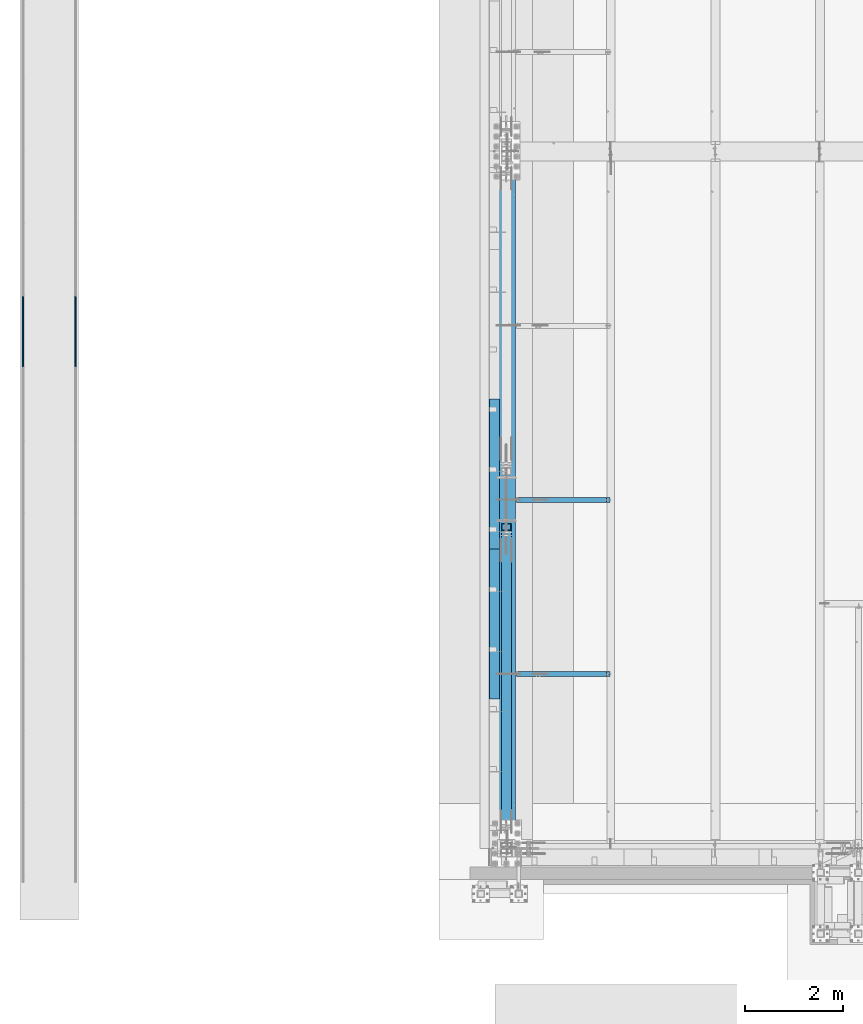
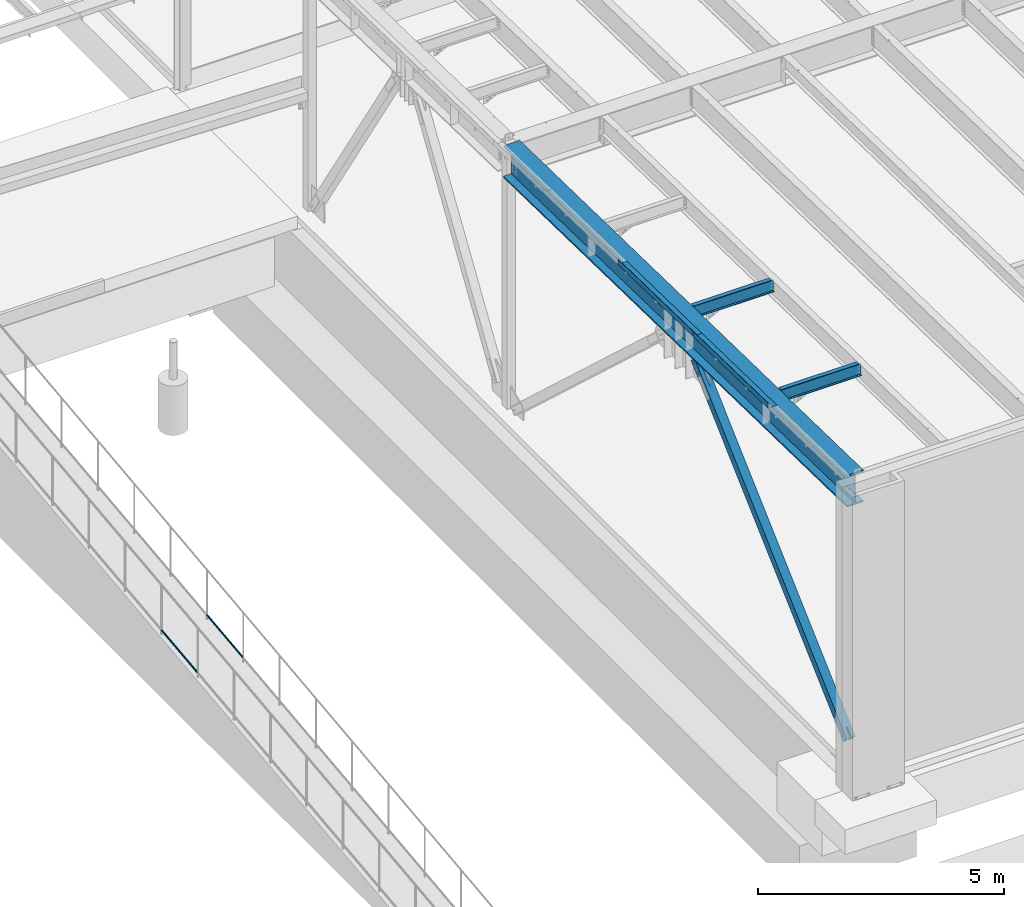
# One storey, part 1035 of 1763: 7 beams, 1 member, 6 elements without a shape of their own.
"""IFC2X3 building model written with IfcOpenShell, lengths in millimetres."""

from ifc_helpers import new_model, si_unit, frame, origin_with_axes, place, context, subcontext, project, spatial, faceted_brep, material, type_object, element, aggregate, save


model = new_model("IFC2X3")

# Units and contexts
model_context = context("Model", 3, precision=1e-05, world=origin_with_axes())
body_context = subcontext(model_context, "Body", "Model", "MODEL_VIEW")
ifc_project = project(units=[si_unit("LENGTHUNIT", "METRE", prefix="MILLI"), si_unit("AREAUNIT", "SQUARE_METRE"), si_unit("VOLUMEUNIT", "CUBIC_METRE"), si_unit("MASSUNIT", "GRAM", prefix="KILO"), si_unit("TIMEUNIT", "SECOND"), si_unit("PLANEANGLEUNIT", "RADIAN"), si_unit("SOLIDANGLEUNIT", "STERADIAN"), si_unit("THERMODYNAMICTEMPERATUREUNIT", "DEGREE_CELSIUS"), si_unit("LUMINOUSINTENSITYUNIT", "LUMEN")], contexts=[model_context])

# Site, building, storey
site_placement = place(None, origin_with_axes())
site = spatial("IfcSite", under=ifc_project, at=site_placement, CompositionType="ELEMENT")
building_placement = place(site_placement, origin_with_axes())
building = spatial("IfcBuilding", under=site, at=building_placement, Name="Undefined", CompositionType="ELEMENT")
storey_placement = place(building_placement, origin_with_axes())
storey = spatial("IfcBuildingStorey", under=building, at=storey_placement, Name="Undefined", CompositionType="ELEMENT", Elevation=0.0)

# Assembly, beam
assembly_1_placement = place(storey_placement, origin_with_axes())
assembly_1 = element("IfcElementAssembly", 1, at=assembly_1_placement, inside=storey, Name="GUARDRAIL", AssemblyPlace="NOTDEFINED", PredefinedType="RIGID_FRAME")
ifc_material_1 = material(Name="STEEL/A513")
beam_type_1 = type_object("IfcBeamType", PredefinedType="NOTDEFINED")
beam_1_placement = place(assembly_1_placement, frame((-97200.6527017878, -3943.56212109816, 4830.43051081101), z_axis=(0.0, -0.114062593029902, 0.993473565260443), x_axis=(0.0, 0.993473565260443, 0.114062593029902)))
beam_1 = element("IfcBeam", 2, at=beam_1_placement, type_object=beam_type_1, material=ifc_material_1, Name="GUARDRAIL", context=body_context, shape_type="Brep", body=[
    faceted_brep([(1468.16665642951, -9.52499999999418, 16.4977839425555), (1467.58900470802, -9.52499999999418, 11.4667123804174), (1467.30376971339, -7.68349999999919, 13.3082123804179), (1465.46783960526, 0.0, 15.3670000004613), (1465.89071001447, 0.0, 19.0500000004622), (1467.3037697134, 7.68349999999919, 13.308212380417), (1467.58900470802, 9.52499999999418, 11.4667123804174), (1468.16665642951, 9.52499999999418, 16.4977839425555), (1482.87860532686, 19.0500000000029, 4.66570782009512e-10), (1474.38465767071, 16.4977839420899, 9.52500000046439), (1472.19739693342, 16.4977839420899, -9.52499999953761), (1470.96269582906, 13.3082123799541, 7.68350000046303), (1472.15281425492, 15.3669999999984, 4.6293280320242e-10), (1469.19830550098, 13.3082123799541, -7.68349999953807), (1464.95586142462, 9.52499999999418, -11.4667123794952), (1464.37820970313, 9.52499999999418, -16.4977839416342), (1464.24775602078, 7.68349999999919, -13.3082123794957), (1461.9390589491, 0.0, -15.3669999995409), (1461.51618853989, 0.0, -19.0499999995409), (1464.95586142462, -9.52499999999418, -11.4667123794952), (1464.37820970313, -9.52499999999418, -16.4977839416342), (1464.24775602078, -7.68349999999919, -13.3082123794948), (1482.87860532695, -19.0500000000029, 4.55656845588237e-10), (1472.19739693342, -16.4977839420899, -9.52499999953761), (1474.38465767071, -16.4977839420899, 9.52500000046439), (1469.19830550097, -13.3082123799541, -7.68349999953807), (1472.15281425491, -15.3669999999984, 4.6293280320242e-10), (1470.96269582905, -13.3082123799541, 7.68350000046303), (8.49463121237, -16.4977839420899, -9.52499999999782), (14.7126324911599, -9.52499999999418, -16.4977839420899), (0.00068350478454704, 19.0500000000029, 0.0), (8.49463121237, 16.4977839420899, -9.52499999999782), (10.6818918337324, 16.4977839420899, 9.52500000000418), (18.5010790167537, 9.52499999999418, 16.4977839421008), (21.3631001626848, 0.0, 19.0500000000075), (14.7126324911599, 9.52499999999418, -16.4977839420899), (16.9885789199607, 0.0, -19.0499999999956), (17.4114493067575, 0.0, -15.3669999999956), (15.2902841820321, -9.52499999999418, -11.4667123799509), (15.575519187561, -7.68349999999919, -13.3082123799513), (15.575519187561, 7.68349999999919, -13.3082123799513), (15.2902841820321, 9.52499999999418, -11.4667123799509), (11.9165930406441, 13.3082123799541, -7.68349999999646), (10.7264745694495, 15.3669999999984, 4.54747350886464e-12), (13.6809832752053, 13.3082123799541, 7.68350000000555), (17.923427325881, 9.52499999999418, 11.4667123799609), (18.631532718199, 7.68349999999919, 13.3082123799622), (20.9402297758882, 0.0, 15.3670000000075), (18.631532718199, -7.68349999999919, 13.3082123799622), (17.923427325881, -9.52499999999418, 11.4667123799609), (18.5010790167537, -9.52499999999418, 16.4977839421008), (10.6818918337324, -16.4977839420899, 9.52500000000418), (0.00068350478454704, -19.0500000000029, 0.0), (13.6809832752053, -13.3082123799541, 7.68350000000555), (10.7264745694495, -15.3669999999984, 4.54747350886464e-12), (11.9165930406441, -13.3082123799541, -7.68349999999646)], [[[0, 1, 2, 3, 4]], [[4, 3, 5, 6, 7]], [[8, 9, 10]], [[7, 6, 11, 12, 13, 14, 15, 10, 9]], [[16, 17, 18, 15, 14]], [[19, 20, 18, 17, 21]], [[22, 23, 24]], [[24, 23, 20, 19, 25, 26, 27, 1, 0]], [[28, 29, 20, 23]], [[30, 31, 32]], [[33, 34, 4, 7]], [[32, 33, 7, 9]], [[30, 32, 9, 8]], [[31, 30, 8, 10]], [[35, 31, 10, 15]], [[36, 35, 15, 18]], [[29, 36, 18, 20]], [[37, 36, 29, 38, 39]], [[40, 41, 35, 36, 37]], [[32, 31, 35, 41, 42, 43, 44, 45, 33]], [[33, 45, 46, 47, 34]], [[34, 47, 48, 49, 50]], [[34, 50, 0, 4]], [[50, 51, 24, 0]], [[51, 52, 22, 24]], [[52, 28, 23, 22]], [[51, 28, 52]], [[50, 49, 53, 54, 55, 38, 29, 28, 51]], [[55, 54, 26, 25]], [[21, 39, 38, 55, 25, 19]], [[37, 39, 21, 17]], [[40, 37, 17, 16]], [[42, 41, 40, 16, 14, 13]], [[43, 42, 13, 12]], [[44, 43, 12, 11]], [[5, 46, 45, 44, 11, 6]], [[47, 46, 5, 3]], [[48, 47, 3, 2]], [[53, 49, 48, 2, 1, 27]], [[54, 53, 27, 26]]]),
])
aggregate(assembly_1, [beam_1])

assembly_2_placement = place(storey_placement, origin_with_axes())
assembly_2 = element("IfcElementAssembly", 3, at=assembly_2_placement, inside=storey, Name="GUARDRAIL", AssemblyPlace="NOTDEFINED", PredefinedType="RIGID_FRAME")
beam_2_placement = place(assembly_2_placement, frame((-96133.8527017878, -3943.56212109816, 4830.43051081101), z_axis=(0.0, -0.114062593029902, 0.993473565260443), x_axis=(0.0, 0.993473565260443, 0.114062593029902)))
beam_2 = element("IfcBeam", 4, at=beam_2_placement, type_object=beam_type_1, material=ifc_material_1, Name="GUARDRAIL", context=body_context, shape_type="Brep", body=[
    faceted_brep([(1468.16665642951, -9.52499999999418, 16.4977839425555), (1467.58900470802, -9.52499999999418, 11.4667123804174), (1467.30376971339, -7.68349999999919, 13.3082123804179), (1465.46783960526, 0.0, 15.3670000004613), (1465.89071001447, 0.0, 19.0500000004622), (1467.3037697134, 7.68349999999919, 13.308212380417), (1467.58900470802, 9.52499999999418, 11.4667123804174), (1468.16665642951, 9.52499999999418, 16.4977839425555), (1482.87860532686, 19.0500000000029, 4.66570782009512e-10), (1474.38465767071, 16.4977839420899, 9.52500000046439), (1472.19739693342, 16.4977839420899, -9.52499999953761), (1470.96269582906, 13.3082123799541, 7.68350000046303), (1472.15281425492, 15.3669999999984, 4.6293280320242e-10), (1469.19830550098, 13.3082123799541, -7.68349999953807), (1464.95586142462, 9.52499999999418, -11.4667123794952), (1464.37820970313, 9.52499999999418, -16.4977839416342), (1464.24775602078, 7.68349999999919, -13.3082123794957), (1461.9390589491, 0.0, -15.3669999995409), (1461.51618853989, 0.0, -19.0499999995409), (1464.95586142462, -9.52499999999418, -11.4667123794952), (1464.37820970313, -9.52499999999418, -16.4977839416342), (1464.24775602078, -7.68349999999919, -13.3082123794948), (1482.87860532695, -19.0500000000029, 4.55656845588237e-10), (1472.19739693342, -16.4977839420899, -9.52499999953761), (1474.38465767071, -16.4977839420899, 9.52500000046439), (1469.19830550097, -13.3082123799541, -7.68349999953807), (1472.15281425491, -15.3669999999984, 4.6293280320242e-10), (1470.96269582905, -13.3082123799541, 7.68350000046303), (8.49463121237, -16.4977839420899, -9.52499999999782), (14.7126324911599, -9.52499999999418, -16.4977839420899), (0.00068350478454704, 19.0500000000029, 0.0), (8.49463121237, 16.4977839420899, -9.52499999999782), (10.6818918337324, 16.4977839420899, 9.52500000000418), (18.5010790167537, 9.52499999999418, 16.4977839421008), (21.3631001626848, 0.0, 19.0500000000075), (14.7126324911599, 9.52499999999418, -16.4977839420899), (16.9885789199607, 0.0, -19.0499999999956), (17.4114493067575, 0.0, -15.3669999999956), (15.2902841820321, -9.52499999999418, -11.4667123799509), (15.575519187561, -7.68349999999919, -13.3082123799513), (15.575519187561, 7.68349999999919, -13.3082123799513), (15.2902841820321, 9.52499999999418, -11.4667123799509), (11.9165930406441, 13.3082123799541, -7.68349999999646), (10.7264745694495, 15.3669999999984, 4.54747350886464e-12), (13.6809832752053, 13.3082123799541, 7.68350000000555), (17.923427325881, 9.52499999999418, 11.4667123799609), (18.631532718199, 7.68349999999919, 13.3082123799622), (20.9402297758882, 0.0, 15.3670000000075), (18.631532718199, -7.68349999999919, 13.3082123799622), (17.923427325881, -9.52499999999418, 11.4667123799609), (18.5010790167537, -9.52499999999418, 16.4977839421008), (10.6818918337324, -16.4977839420899, 9.52500000000418), (0.00068350478454704, -19.0500000000029, 0.0), (13.6809832752053, -13.3082123799541, 7.68350000000555), (10.7264745694495, -15.3669999999984, 4.54747350886464e-12), (11.9165930406441, -13.3082123799541, -7.68349999999646)], [[[0, 1, 2, 3, 4]], [[4, 3, 5, 6, 7]], [[8, 9, 10]], [[7, 6, 11, 12, 13, 14, 15, 10, 9]], [[16, 17, 18, 15, 14]], [[19, 20, 18, 17, 21]], [[22, 23, 24]], [[24, 23, 20, 19, 25, 26, 27, 1, 0]], [[28, 29, 20, 23]], [[30, 31, 32]], [[33, 34, 4, 7]], [[32, 33, 7, 9]], [[30, 32, 9, 8]], [[31, 30, 8, 10]], [[35, 31, 10, 15]], [[36, 35, 15, 18]], [[29, 36, 18, 20]], [[37, 36, 29, 38, 39]], [[40, 41, 35, 36, 37]], [[32, 31, 35, 41, 42, 43, 44, 45, 33]], [[33, 45, 46, 47, 34]], [[34, 47, 48, 49, 50]], [[34, 50, 0, 4]], [[50, 51, 24, 0]], [[51, 52, 22, 24]], [[52, 28, 23, 22]], [[51, 28, 52]], [[50, 49, 53, 54, 55, 38, 29, 28, 51]], [[55, 54, 26, 25]], [[21, 39, 38, 55, 25, 19]], [[37, 39, 21, 17]], [[40, 37, 17, 16]], [[42, 41, 40, 16, 14, 13]], [[43, 42, 13, 12]], [[44, 43, 12, 11]], [[5, 46, 45, 44, 11, 6]], [[47, 46, 5, 3]], [[48, 47, 3, 2]], [[53, 49, 48, 2, 1, 27]], [[54, 53, 27, 26]]]),
])
aggregate(assembly_2, [beam_2])

# Assembly, beams
assembly_3_placement = place(storey_placement, origin_with_axes())
assembly_3 = element("IfcElementAssembly", 5, at=assembly_3_placement, inside=storey, Name="BEAM", AssemblyPlace="NOTDEFINED", PredefinedType="RIGID_FRAME")
ifc_material_2 = material(Name="STEEL/A36")
beam_type_2 = type_object("IfcBeamType", PredefinedType="NOTDEFINED")
beam_3_placement = place(assembly_3_placement, frame((-87516.7242736983, -6103.92192521473, 12048.7381765459), z_axis=(0.0, -0.999781542838788, 0.0209013539966307), x_axis=(-1.0, 0.0, 0.0)))
beam_3 = element("IfcBeam", 6, at=beam_3_placement, type_object=beam_type_2, material=ifc_material_2, Name="BENT_PLATE", context=body_context, shape_type="Brep", body=[
    faceted_brep([(0.0, -3.17499999999927, -1523.99999999999), (0.0, -3.17499999999927, 1524.0), (0.0, 3.17499999999927, 1524.0), (0.0, 3.17499999999927, -1523.99999999999), (207.962982177749, 3.17499999952452, 1524.00000000123), (207.96298217772, 3.17500000052678, -1524.00000000122), (201.612982177714, -3.17499999947904, -1524.00000000123), (201.612982177743, -3.1750000004813, 1524.00000000122), (207.962982177734, -123.82500358932, 1524.00000000118), (207.962982177734, -123.825003588276, -1524.00000000127), (201.612982177729, -123.82500358932, 1524.00000000118), (201.612982177729, -123.825003588276, -1524.00000000127)], [[[0, 1, 2, 3]], [[3, 2, 4, 5]], [[1, 0, 6, 7]], [[5, 4, 8, 9]], [[4, 2, 1, 7, 10, 8]], [[7, 6, 11, 10]], [[6, 0, 3, 5, 9, 11]], [[10, 11, 9, 8]]]),
])
beam_4_placement = place(assembly_3_placement, frame((-87516.7242736983, -9151.2560676624, 12112.445509622), z_axis=(0.0, -0.999781542838788, 0.0209013539966307), x_axis=(-1.0, 0.0, 0.0)))
beam_4 = element("IfcBeam", 7, at=beam_4_placement, type_object=beam_type_2, material=ifc_material_2, Name="BENT_PLATE", context=body_context, shape_type="Brep", body=[
    faceted_brep([(0.0, -3.17499999999927, -1523.99999999999), (0.0, -3.17499999999927, 1524.0), (0.0, 3.17499999999927, 1524.0), (0.0, 3.17499999999927, -1523.99999999999), (207.962982177749, 3.17499999952452, 1524.00000000123), (207.96298217772, 3.17500000052678, -1524.00000000122), (201.612982177714, -3.17499999947904, -1524.00000000123), (201.612982177743, -3.1750000004813, 1524.00000000122), (207.962982177734, -123.82500358932, 1524.00000000118), (207.962982177734, -123.825003588276, -1524.00000000127), (201.612982177729, -123.82500358932, 1524.00000000118), (201.612982177729, -123.825003588276, -1524.00000000127)], [[[0, 1, 2, 3]], [[3, 2, 4, 5]], [[1, 0, 6, 7]], [[5, 4, 8, 9]], [[4, 2, 1, 7, 10, 8]], [[7, 6, 11, 10]], [[6, 0, 3, 5, 9, 11]], [[10, 11, 9, 8]]]),
])

# Assembly, beam
assembly_4_placement = place(storey_placement, origin_with_axes())
assembly_4 = element("IfcElementAssembly", 8, at=assembly_4_placement, inside=storey, Name="BEAM", AssemblyPlace="NOTDEFINED", PredefinedType="RIGID_FRAME")
ifc_material_3 = material(Name="STEEL/A992")
beam_type_3 = type_object("IfcBeamType", Name="W12X22", PredefinedType="NOTDEFINED")
beam_5_placement = place(assembly_4_placement, frame((-87375.4372736983, -10172.7000000134, 11975.0490441139), z_axis=(0.0, 0.0, 1.0), x_axis=(1.0, 0.0, 0.0)))
beam_5 = element("IfcBeam", 9, at=beam_5_placement, type_object=beam_type_3, material=ifc_material_3, Name="BEAM", ObjectType="W12X22", context=body_context, shape_type="Brep", body=[
    faceted_brep([(20.6374999999971, -3.17499999999927, -123.824999999781), (20.6374999999971, 3.17499999999927, -123.824999999781), (198.437500190732, 3.17500001932785, -123.824999999781), (198.437500190732, -3.17500000000018, -123.824999999781), (203.297579708771, 3.17500001940971, -124.791729922368), (203.297579708771, -3.17500000000018, -124.791729922368), (207.417756176932, 3.17500001964163, -127.544743822846), (207.417756176932, -3.17500000000018, -127.544743822846), (210.170770077413, 3.17500001998906, -131.664920290999), (210.170770077413, -3.17500000000018, -131.664920290999), (211.137499999997, -3.17500000000018, -136.524999809046), (211.137499999997, 3.17500002039924, -136.524999809046), (211.137499999997, 3.17500004775593, -144.4625), (211.137499999997, 50.8000000000002, -144.4625), (211.137499999997, 50.8000000000002, -155.575000000001), (211.137499999997, -50.8000000000002, -155.575000000001), (211.137499999997, -50.8000000000002, -144.4625), (211.137499999997, -3.17500000000018, -144.4625), (2033.47410714286, 50.7999999999993, 144.4625), (2033.47410714286, 3.17499999999927, 144.4625), (211.137499999997, 3.17500000000018, 144.4625), (211.137499999997, 50.8000000000002, 144.4625), (198.437500190732, -3.17500000000018, 111.12500000022), (198.437500190732, 3.17499999968732, 111.12500000022), (20.6374999999971, 3.17499999999927, 111.12500000022), (20.6374999999971, -3.17499999999927, 111.12500000022), (203.297579708771, -3.17500000000018, 112.091729922808), (203.297579708771, 3.17499999960637, 112.091729922808), (207.417756176932, -3.17500000000018, 114.844743823285), (207.417756176932, 3.17499999937718, 114.844743823285), (210.170770077413, -3.17500000000018, 118.964920291439), (210.170770077413, 3.1749999990343, 118.964920291439), (211.137499999997, -3.17500000000018, 123.824999809485), (211.137499999997, 3.17499999862866, 123.824999809485), (2033.47410714286, -50.7999999999993, 155.575000000001), (2033.47410714286, 50.7999999999993, 155.575000000001), (211.137499999997, 50.8000000000002, 155.575000000001), (211.137499999997, -50.8000000000002, 155.575000000001), (2033.47410714286, -50.7999999999993, 144.4625), (211.137499999997, -50.8000000000002, 144.4625), (2033.47410714286, -3.17499999999927, 144.4625), (211.137499999997, -3.17500000000018, 144.4625), (2033.47410714286, -3.17499999999927, 136.265001487105), (2033.47410714286, 3.17499999999927, 136.265001487105), (2034.44083706544, -3.17499999999927, 131.404921969059), (2034.44083706544, 3.17499999999927, 131.404921969059), (2037.19385096592, -3.17499999999927, 127.284745500905), (2037.19385096592, 3.17499999999927, 127.284745500905), (2041.31402743408, -3.17499999999927, 124.531731600428), (2041.31402743408, 3.17499999999927, 124.531731600428), (2046.17410695212, -3.17499999999927, 123.56500167784), (2046.17410695212, 3.17499999999927, 123.56500167784), (2109.67410714286, -3.17499999999927, 123.56500167784), (2109.67410714286, 3.17499999999927, 123.56500167784), (2109.67410714286, -3.17499999999927, -144.4625), (2109.67410714286, -50.7999999999993, -144.4625), (2109.67410714286, -50.7999999999993, -155.575000000001), (2109.67410714286, 50.7999999999993, -155.575000000001), (2109.67410714286, 50.7999999999993, -144.4625), (2109.67410714286, 3.17499999999927, -144.4625)], [[[0, 1, 2, 3]], [[3, 2, 4, 5]], [[5, 4, 6, 7]], [[7, 6, 8, 9]], [[10, 11, 12, 13, 14, 15, 16, 17]], [[9, 8, 11, 10]], [[18, 19, 20, 21]], [[22, 23, 24, 25]], [[26, 27, 23, 22]], [[28, 29, 27, 26]], [[30, 31, 29, 28]], [[32, 33, 31, 30]], [[34, 35, 36, 37]], [[38, 34, 37, 39]], [[40, 38, 39, 41]], [[37, 36, 21, 20, 33, 32, 41, 39]], [[35, 18, 21, 36]], [[34, 38, 40, 42, 43, 19, 18, 35]], [[44, 45, 43, 42]], [[46, 47, 45, 44]], [[48, 49, 47, 46]], [[50, 51, 49, 48]], [[52, 53, 51, 50]], [[54, 55, 56, 57, 58, 59, 53, 52]], [[55, 54, 17, 16]], [[56, 55, 16, 15]], [[57, 56, 15, 14]], [[58, 57, 14, 13]], [[59, 58, 13, 12]], [[6, 4, 2, 1, 24, 23, 27, 29, 31, 33, 20, 19, 43, 45, 47, 49, 51, 53, 59, 12, 11, 8]], [[25, 24, 1, 0]], [[54, 52, 50, 48, 46, 44, 42, 40, 41, 32, 30, 28, 26, 22, 25, 0, 3, 5, 7, 9, 10, 17]]]),
])
aggregate(assembly_4, [beam_5])

assembly_5_placement = place(storey_placement, origin_with_axes())
assembly_5 = element("IfcElementAssembly", 10, at=assembly_5_placement, inside=storey, Name="BEAM", AssemblyPlace="NOTDEFINED", PredefinedType="RIGID_FRAME")
beam_6_placement = place(assembly_5_placement, frame((-87375.4372736983, -6629.39997031122, 11900.9730863668), z_axis=(0.0, 0.0, 1.0), x_axis=(1.0, 0.0, 0.0)))
beam_6 = element("IfcBeam", 11, at=beam_6_placement, type_object=beam_type_3, material=ifc_material_3, Name="BEAM", ObjectType="W12X22", context=body_context, shape_type="Brep", body=[
    faceted_brep([(20.6374999999971, -3.17499999999927, -123.824999999781), (20.6374999999971, 3.17499999999927, -123.824999999781), (198.437500190732, 3.17500001932785, -123.824999999781), (198.437500190732, -3.17500000000018, -123.824999999781), (203.297579708771, 3.17500001940971, -124.791729922368), (203.297579708771, -3.17500000000018, -124.791729922368), (207.417756176932, 3.17500001964163, -127.544743822846), (207.417756176932, -3.17500000000018, -127.544743822846), (210.170770077413, 3.17500001998906, -131.664920290999), (210.170770077413, -3.17500000000018, -131.664920290999), (211.137499999997, -3.17500000000018, -136.524999809046), (211.137499999997, 3.17500002039924, -136.524999809046), (211.137499999997, 3.17500004775593, -144.4625), (211.137499999997, 50.8000000000002, -144.4625), (211.137499999997, 50.8000000000002, -155.575000000001), (211.137499999997, -50.8000000000002, -155.575000000001), (211.137499999997, -50.8000000000002, -144.4625), (211.137499999997, -3.17500000000018, -144.4625), (2033.47410714286, 50.7999999999993, 144.4625), (2033.47410714286, 3.17499999999927, 144.4625), (211.137499999997, 3.17500000000018, 144.4625), (211.137499999997, 50.8000000000002, 144.4625), (198.437500190732, -3.17500000000018, 111.12500000022), (198.437500190732, 3.17499999968732, 111.12500000022), (20.6374999999971, 3.17499999999927, 111.12500000022), (20.6374999999971, -3.17499999999927, 111.12500000022), (203.297579708771, -3.17500000000018, 112.091729922808), (203.297579708771, 3.17499999960637, 112.091729922808), (207.417756176932, -3.17500000000018, 114.844743823285), (207.417756176932, 3.17499999937718, 114.844743823285), (210.170770077413, -3.17500000000018, 118.964920291439), (210.170770077413, 3.1749999990343, 118.964920291439), (211.137499999997, -3.17500000000018, 123.824999809485), (211.137499999997, 3.17499999862866, 123.824999809485), (2033.47410714286, -50.7999999999993, 155.575000000001), (2033.47410714286, 50.7999999999993, 155.575000000001), (211.137499999997, 50.8000000000002, 155.575000000001), (211.137499999997, -50.8000000000002, 155.575000000001), (2033.47410714286, -50.7999999999993, 144.4625), (211.137499999997, -50.8000000000002, 144.4625), (2033.47410714286, -3.17499999999927, 144.4625), (211.137499999997, -3.17500000000018, 144.4625), (2033.47410714286, -3.17499999999927, 136.265001487105), (2033.47410714286, 3.17499999999927, 136.265001487105), (2034.44083706544, -3.17499999999927, 131.404921969059), (2034.44083706544, 3.17499999999927, 131.404921969059), (2037.19385096592, -3.17499999999927, 127.284745500905), (2037.19385096592, 3.17499999999927, 127.284745500905), (2041.31402743408, -3.17499999999927, 124.531731600428), (2041.31402743408, 3.17499999999927, 124.531731600428), (2046.17410695212, -3.17499999999927, 123.56500167784), (2046.17410695212, 3.17499999999927, 123.56500167784), (2109.67410714286, -3.17499999999927, 123.56500167784), (2109.67410714286, 3.17499999999927, 123.56500167784), (2109.67410714286, -3.17499999999927, -144.4625), (2109.67410714286, -50.7999999999993, -144.4625), (2109.67410714286, -50.7999999999993, -155.575000000001), (2109.67410714286, 50.7999999999993, -155.575000000001), (2109.67410714286, 50.7999999999993, -144.4625), (2109.67410714286, 3.17499999999927, -144.4625)], [[[0, 1, 2, 3]], [[3, 2, 4, 5]], [[5, 4, 6, 7]], [[7, 6, 8, 9]], [[10, 11, 12, 13, 14, 15, 16, 17]], [[9, 8, 11, 10]], [[18, 19, 20, 21]], [[22, 23, 24, 25]], [[26, 27, 23, 22]], [[28, 29, 27, 26]], [[30, 31, 29, 28]], [[32, 33, 31, 30]], [[34, 35, 36, 37]], [[38, 34, 37, 39]], [[40, 38, 39, 41]], [[37, 36, 21, 20, 33, 32, 41, 39]], [[35, 18, 21, 36]], [[34, 38, 40, 42, 43, 19, 18, 35]], [[44, 45, 43, 42]], [[46, 47, 45, 44]], [[48, 49, 47, 46]], [[50, 51, 49, 48]], [[52, 53, 51, 50]], [[54, 55, 56, 57, 58, 59, 53, 52]], [[55, 54, 17, 16]], [[56, 55, 16, 15]], [[57, 56, 15, 14]], [[58, 57, 14, 13]], [[59, 58, 13, 12]], [[6, 4, 2, 1, 24, 23, 27, 29, 31, 33, 20, 19, 43, 45, 47, 49, 51, 53, 59, 12, 11, 8]], [[25, 24, 1, 0]], [[54, 52, 50, 48, 46, 44, 42, 40, 41, 32, 30, 28, 26, 22, 25, 0, 3, 5, 7, 9, 10, 17]]]),
])
aggregate(assembly_5, [beam_6])

# Assembly, member
assembly_6_placement = place(storey_placement, origin_with_axes())
assembly_6 = element("IfcElementAssembly", 12, at=assembly_6_placement, inside=storey, Name="V. BRACE", AssemblyPlace="NOTDEFINED", PredefinedType="RIGID_FRAME")
ifc_material_4 = material()
member_type = type_object("IfcMemberType", Name="HSS8X8X1/2", PredefinedType="NOTDEFINED")
member_placement = place(assembly_6_placement, frame((-87375.4372736983, -13716.0, 5130.8), z_axis=(0.0, -0.677746873297467, 0.735295298322726), x_axis=(0.0, 0.735295298322726, 0.677746873297467)))
member = element("IfcMember", 13, at=member_placement, type_object=member_type, material=ifc_material_4, Name="V. BRACE", ObjectType="HSS8X8X1/2", context=body_context, shape_type="Brep", body=[
    faceted_brep([(8890.610834791, 11.1125003814668, 101.600000002425), (8255.61085519514, 11.1125003814668, 101.600000002254), (8255.61085519515, 11.1125003814668, 88.9000000022497), (8890.610834791, 11.1125003814668, 88.9000000024189), (8251.96579564785, 10.3874529576715, 101.600000002254), (8251.96579564785, 10.3874529576715, 88.9000000022497), (8248.87566337408, 8.32269258399901, 101.600000002252), (8248.87566337409, 8.32269258399901, 88.9000000022461), (8246.81090300041, 5.23256031023629, 101.600000002252), (8246.81090300042, 5.23256031023629, 88.9000000022461), (8246.08585557662, 1.58750076293654, 101.600000002252), (8246.08585557663, 1.58750076293654, 88.9000000022461), (8246.08585557662, -1.58750038147264, 101.600000002252), (8246.08585557663, -1.58750038147264, 88.9000000022461), (8246.81090300041, -5.23255992877239, 101.600000002252), (8246.81090300042, -5.23255992877239, 88.9000000022461), (8248.87566337408, -8.32269220253511, 101.600000002252), (8248.87566337409, -8.32269220253511, 88.9000000022461), (8251.96579564785, -10.3874525762076, 101.600000002254), (8251.96579564785, -10.3874525762076, 88.9000000022497), (8255.61085519514, -11.1125000000029, 101.600000002254), (8255.61085519515, -11.1125000000029, 88.9000000022497), (8890.610834791, -11.1125000000029, 101.600000002425), (8890.610834791, -11.1125000000029, 88.9000000024189), (8890.61083479102, 11.1125003814668, -88.8999999976659), (8255.6108551952, 11.1125003814668, -88.899999997835), (8255.61085519521, 11.1125003814668, -101.599999997841), (8890.61083479102, 11.1125003814668, -101.59999999767), (8251.96579564791, 10.3874529576715, -88.899999997835), (8251.96579564792, 10.3874529576715, -101.599999997841), (8248.87566337415, 8.32269258399901, -88.899999997835), (8248.87566337415, 8.32269258399901, -101.599999997841), (8246.81090300048, 5.23256031023629, -88.8999999978369), (8246.81090300048, 5.23256031023629, -101.599999997843), (8246.08585557668, 1.58750076293654, -88.8999999978369), (8246.08585557669, 1.58750076293654, -101.599999997843), (8246.08585557668, -1.58750038147264, -88.8999999978369), (8246.08585557669, -1.58750038147264, -101.599999997843), (8246.81090300048, -5.23255992877239, -88.8999999978369), (8246.81090300048, -5.23255992877239, -101.599999997843), (8248.87566337415, -8.32269220253511, -88.899999997835), (8248.87566337415, -8.32269220253511, -101.599999997841), (8251.96579564791, -10.3874525762076, -88.899999997835), (8251.96579564792, -10.3874525762076, -101.599999997841), (8255.6108551952, -11.1125000000029, -88.899999997835), (8255.61085519521, -11.1125000000029, -101.599999997841), (8890.61083479102, -11.1125000000029, -88.8999999976659), (8890.61083479102, -11.1125000000029, -101.59999999767), (484.966364630503, 88.8999999999942, 88.9000000001724), (484.966364630512, 88.8999999999942, -88.8999999999123), (8890.61083479102, 88.8999999999942, -88.8999999976659), (8890.610834791, 88.8999999999942, 88.9000000024189), (8890.610834791, -88.8999999999942, 88.9000000024189), (484.966364630503, -88.8999999999942, 88.9000000001724), (484.966364630503, -14.2874999999913, 88.9000000001724), (713.566372206521, -14.2874999999913, 88.9000000002343), (718.426451724556, -13.3207700774074, 88.9000000002343), (722.546628192698, -10.5677561769262, 88.9000000002343), (725.29964209317, -6.44757970876526, 88.9000000002361), (726.266372015754, -1.58750019072613, 88.9000000002379), (726.266372015754, 1.58750095368305, 88.9000000002379), (725.29964209317, 6.44758047172218, 88.9000000002361), (722.546628192698, 10.5677569398831, 88.9000000002343), (718.426451724556, 13.3207708403643, 88.9000000002343), (713.566372206521, 14.2875007629482, 88.9000000002343), (484.966364630503, 14.2875007629482, 88.9000000001724), (484.966364630512, -88.8999999999942, -88.8999999999123), (8890.61083479102, -88.8999999999942, -88.8999999976659), (484.966364630512, 14.2875007629482, -88.8999999999123), (713.566372206587, 14.2875007629482, -88.8999999998487), (718.426451724621, 13.3207708403643, -88.8999999998487), (722.546628192766, 10.5677569398831, -88.8999999998487), (725.299642093236, 6.44758047172218, -88.8999999998468), (726.266372015823, 1.58750095368305, -88.8999999998487), (726.266372015823, -1.58750019072613, -88.8999999998487), (725.299642093236, -6.44757970876526, -88.8999999998468), (722.546628192766, -10.5677561769262, -88.8999999998487), (718.426451724621, -13.3207700774074, -88.8999999998487), (713.566372206587, -14.2874999999913, -88.8999999998487), (484.966364630512, -14.2874999999913, -88.8999999999123), (484.966364630512, 14.2875007629482, -101.599999999917), (713.566372206593, 14.2875007629482, -101.599999999857), (718.426451724627, 13.3207708403643, -101.599999999855), (722.546628192771, 10.5677569398831, -101.599999999855), (725.299642093241, 6.44758047172218, -101.599999999853), (726.266372015826, 1.58750095368305, -101.599999999853), (726.266372015826, -1.58750019072613, -101.599999999853), (725.299642093241, -6.44757970876526, -101.599999999853), (722.546628192771, -10.5677561769262, -101.599999999855), (718.426451724627, -13.3207700774074, -101.599999999855), (713.566372206593, -14.2874999999913, -101.599999999857), (484.966364630512, -14.2874999999913, -101.599999999917), (484.966364630512, -101.600000000006, -101.599999999917), (484.966364630501, -101.600000000006, 101.600000000179), (484.966364630501, -14.2874999999913, 101.600000000179), (713.566372206516, -14.2874999999913, 101.600000000239), (718.426451724552, -13.3207700774074, 101.60000000024), (722.546628192694, -10.5677561769262, 101.600000000242), (725.299642093165, -6.44757970876526, 101.600000000242), (726.266372015751, -1.58750019072613, 101.600000000242), (726.266372015751, 1.58750095368305, 101.600000000242), (725.299642093165, 6.44758047172218, 101.600000000242), (722.546628192694, 10.5677569398831, 101.600000000242), (718.426451724552, 13.3207708403643, 101.60000000024), (713.566372206516, 14.2875007629482, 101.600000000239), (484.966364630501, 14.2875007629482, 101.600000000179), (484.966364630501, 101.600000000006, 101.600000000179), (484.966364630512, 101.600000000006, -101.599999999917), (8890.610834791, 101.600000000006, 101.600000002425), (8890.61083479102, 101.600000000006, -101.59999999767), (8890.61083479102, -101.600000000006, -101.59999999767), (8890.610834791, -101.600000000006, 101.600000002425)], [[[0, 1, 2, 3]], [[4, 5, 2, 1]], [[6, 7, 5, 4]], [[8, 9, 7, 6]], [[10, 11, 9, 8]], [[12, 13, 11, 10]], [[14, 15, 13, 12]], [[16, 17, 15, 14]], [[18, 19, 17, 16]], [[20, 21, 19, 18]], [[22, 23, 21, 20]], [[24, 25, 26, 27]], [[28, 29, 26, 25]], [[30, 31, 29, 28]], [[32, 33, 31, 30]], [[34, 35, 33, 32]], [[36, 37, 35, 34]], [[38, 39, 37, 36]], [[40, 41, 39, 38]], [[42, 43, 41, 40]], [[44, 45, 43, 42]], [[46, 47, 45, 44]], [[48, 49, 50, 51]], [[52, 53, 54, 55, 56, 57, 58, 59, 60, 61, 62, 63, 64, 65, 48, 51, 3, 2, 5, 7, 9, 11, 13, 15, 17, 19, 21, 23]], [[66, 53, 52, 67]], [[42, 40, 38, 36, 34, 32, 30, 28, 25, 24, 50, 49, 68, 69, 70, 71, 72, 73, 74, 75, 76, 77, 78, 79, 66, 67, 46, 44]], [[68, 80, 81, 69]], [[69, 81, 82, 70]], [[70, 82, 83, 71]], [[71, 83, 84, 72]], [[72, 84, 85, 73]], [[73, 85, 86, 74]], [[74, 86, 87, 75]], [[75, 87, 88, 76]], [[76, 88, 89, 77]], [[77, 89, 90, 78]], [[78, 90, 91, 79]], [[53, 66, 79, 91, 92, 93, 94, 54]], [[95, 55, 54, 94]], [[96, 56, 55, 95]], [[97, 57, 56, 96]], [[98, 58, 57, 97]], [[99, 59, 58, 98]], [[100, 60, 59, 99]], [[101, 61, 60, 100]], [[102, 62, 61, 101]], [[103, 63, 62, 102]], [[104, 64, 63, 103]], [[105, 65, 64, 104]], [[106, 107, 80, 68, 49, 48, 65, 105]], [[107, 106, 108, 109]], [[51, 50, 24, 27, 109, 108, 0, 3]], [[110, 92, 91, 90, 89, 88, 87, 86, 85, 84, 83, 82, 81, 80, 107, 109, 27, 26, 29, 31, 33, 35, 37, 39, 41, 43, 45, 47]], [[93, 92, 110, 111]], [[18, 16, 14, 12, 10, 8, 6, 4, 1, 0, 108, 106, 105, 104, 103, 102, 101, 100, 99, 98, 97, 96, 95, 94, 93, 111, 22, 20]], [[111, 110, 47, 46, 67, 52, 23, 22]]]),
])
aggregate(assembly_6, [member])

# Beam
beam_type_4 = type_object("IfcBeamType", Name="W30X211", PredefinedType="NOTDEFINED")
beam_7_placement = place(assembly_3_placement, frame((-87375.4372736983, -13724.2288046593, 11811.0860066027), z_axis=(0.0, 0.0209013539966291, 0.999781542838788), x_axis=(0.0, 0.999781542776098, -0.0209013569953182)))
beam_7 = element("IfcBeam", 14, at=beam_7_placement, type_object=beam_type_4, material=ifc_material_3, Name="BEAM", ObjectType="W30X211", context=body_context, shape_type="Brep", body=[
    faceted_brep([(130.786239711128, 192.087499999994, -393.700000000359), (130.089288501607, 192.087499999994, -360.362500000332), (14077.7362524684, 192.087499999994, -360.362500004927), (14078.4332036779, 192.087499999994, -393.700000004954), (130.089288501607, 9.52499999999418, -360.362500000332), (14077.7362524684, 9.52499999999418, -360.362500004927), (115.02186711482, 9.52499999999418, 360.362500000252), (14062.6688310816, 9.52499999999418, 360.362499995657), (115.02186711482, 192.087499999994, 360.362500000252), (14062.6688310816, 192.087499999994, 360.362499995657), (114.324915905299, 192.087499999994, 393.700000000279), (14061.9718798721, 192.087499999994, 393.699999995682), (114.324915905299, -192.087499999994, 393.700000000279), (14061.9718798721, -192.087499999994, 393.699999995682), (115.02186711482, -192.087499999994, 360.362500000252), (14062.6688310816, -192.087499999994, 360.362499995657), (115.02186711482, -9.52499999999418, 360.362500000252), (14062.6688310816, -9.52499999999418, 360.362499995657), (130.089288501607, -9.52499999999418, -360.362500000332), (14077.7362524684, -9.52499999999418, -360.362500004927), (130.089288501607, -192.087499999994, -360.362500000332), (14077.7362524684, -192.087499999994, -360.362500004927), (130.786239711128, -192.087499999994, -393.700000000359), (14078.4332036779, -192.087499999994, -393.700000004954)], [[[0, 1, 2, 3]], [[1, 4, 5, 2]], [[4, 6, 7, 5]], [[6, 8, 9, 7]], [[8, 10, 11, 9]], [[10, 12, 13, 11]], [[12, 14, 15, 13]], [[14, 16, 17, 15]], [[16, 18, 19, 17]], [[18, 20, 21, 19]], [[20, 22, 23, 21]], [[22, 0, 3, 23]], [[5, 7, 9, 11, 13, 15, 17, 19, 21, 23, 3, 2]], [[22, 20, 18, 16, 14, 12, 10, 8, 6, 4, 1, 0]]]),
])

aggregate(assembly_3, [beam_3, beam_4, beam_7])

save(model, "model.ifc")
